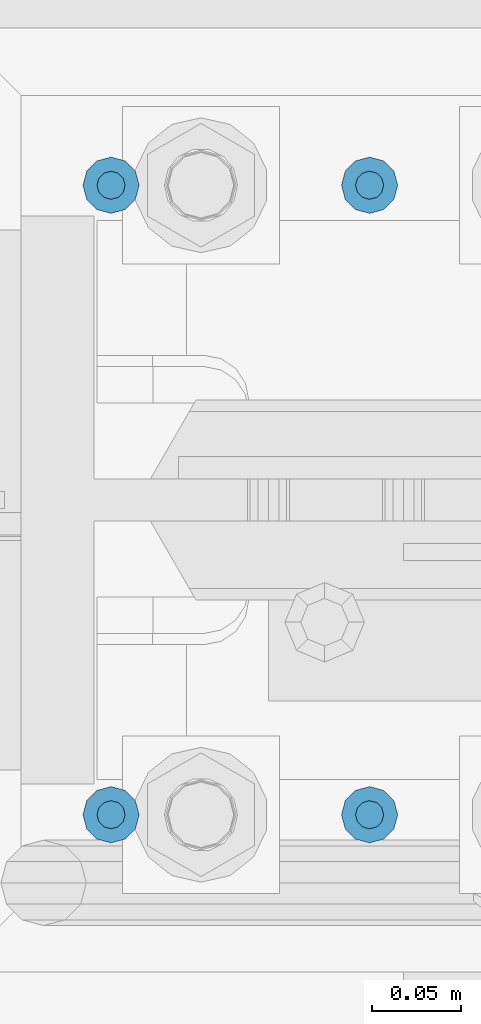
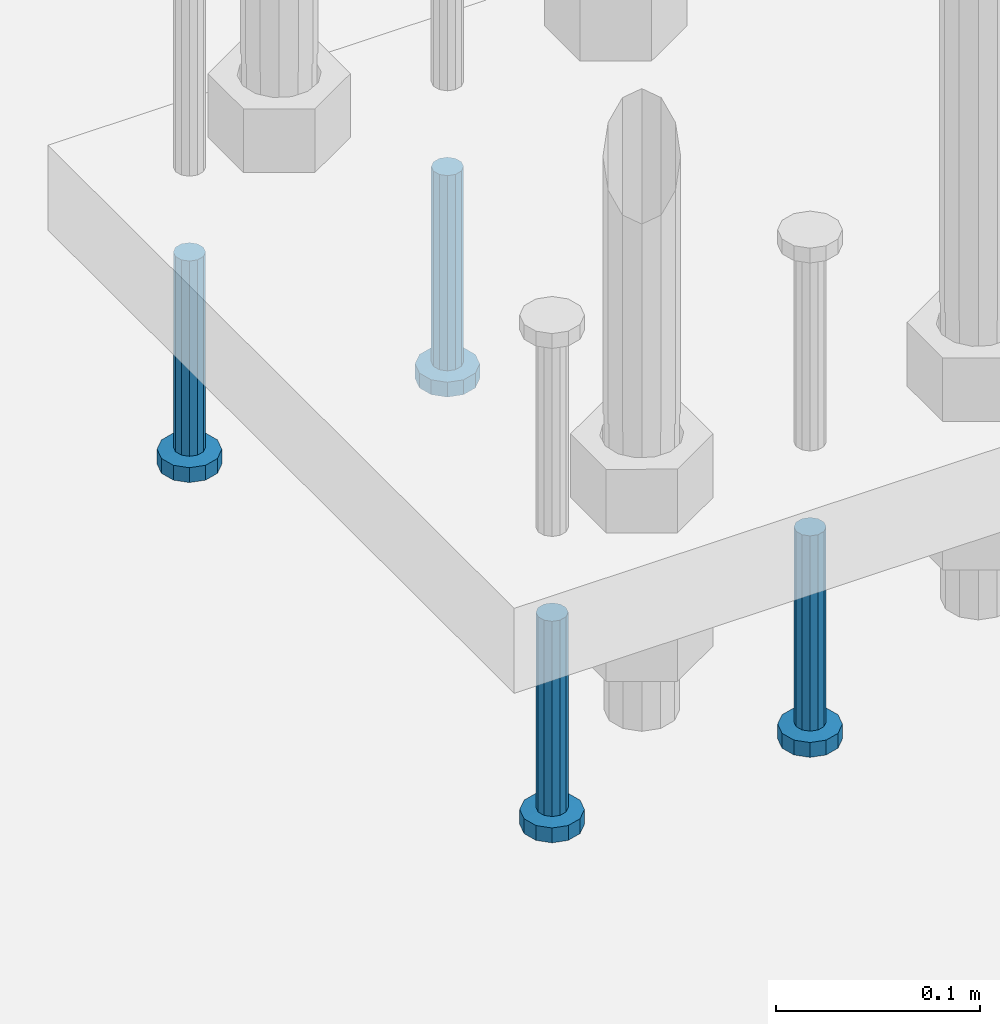
# One storey, part 1333 of 1876: 4 beams, 1 element without a shape of its own.
"""IFC2X3 building model written with IfcOpenShell, lengths in millimetres."""

import ifcopenshell
import ifcopenshell.guid

model = None  # the IFC model being written
_history = None  # IfcOwnerHistory: only IFC2X3 demands one
_inside = {}  # id of a spatial element -> (the spatial element, [elements in it])
_under = {}  # id of a project, library or spatial element -> (it, [spatial elements below it])
_declared = {}  # id of a project -> (the project, [libraries it declares])
_typed = {}  # id of a type object -> (the type object, [elements of that type])
_made_of = {}  # id of a material, layer set ... -> (it, [elements and type objects made of it])


def new_model(schema):
    """Start an empty IFC model of exactly this schema.

    Asked for "IFC4X3", IfcOpenShell would pick the latest addendum, in which some entities
    have other attributes; the version numbers below select the first issue.
    IFC2X3 requires an IfcOwnerHistory on every rooted entity: one is made here for all.
    """
    global model, _history
    if schema == "IFC4X3":
        model = ifcopenshell.file(schema_version=(4, 3, 0, 0))
    else:
        model = ifcopenshell.file(schema=schema)
    _inside.clear()
    _under.clear()
    _declared.clear()
    _typed.clear()
    _made_of.clear()
    _history = None
    if model.schema == "IFC2X3":
        org = make("IfcOrganization", Name="unknown")
        user = make(
            "IfcPersonAndOrganization",
            ThePerson=make("IfcPerson", FamilyName="unknown"),
            TheOrganization=org,
        )
        app = make(
            "IfcApplication",
            ApplicationDeveloper=org,
            Version="unknown",
            ApplicationFullName="unknown",
            ApplicationIdentifier="unknown",
        )
        _history = make(
            "IfcOwnerHistory",
            OwningUser=user,
            OwningApplication=app,
            ChangeAction="ADDED",
            CreationDate=0,
        )
    return model


def make(cls, **values):
    """One entity of the class cls with the attributes given. An attribute that is None is left unset."""
    return model.create_entity(
        cls, **{name: value for name, value in values.items() if value is not None}
    )


def rooted(cls, **values):
    """An entity with a GlobalId (a new one), such as an element, a storey or a relation."""
    return make(cls, GlobalId=ifcopenshell.guid.new(), OwnerHistory=_history, **values)


def si_unit(unit_type, name, prefix=None):
    """IfcSIUnit, for example si_unit("LENGTHUNIT", "METRE", prefix="MILLI")."""
    return make("IfcSIUnit", UnitType=unit_type, Prefix=prefix, Name=name)


def assignment(units):
    """IfcUnitAssignment: the units of a project."""
    return None if units is None else make("IfcUnitAssignment", Units=units)


def point(xyz):
    """IfcCartesianPoint."""
    return None if xyz is None else make("IfcCartesianPoint", Coordinates=xyz)


def direction(xyz):
    """IfcDirection."""
    return None if xyz is None else make("IfcDirection", DirectionRatios=xyz)


def frame(location, z_axis=None, x_axis=None):
    """IfcAxis2Placement3D, a coordinate frame: its origin and axes. An axis left out is left unset."""
    return make(
        "IfcAxis2Placement3D",
        Location=point(location),
        Axis=direction(z_axis),
        RefDirection=direction(x_axis),
    )


def origin_with_axes():
    """The frame at (0, 0, 0) with the z axis (0, 0, 1) and the x axis (1, 0, 0) written out."""
    return frame((0.0, 0.0, 0.0), z_axis=(0.0, 0.0, 1.0), x_axis=(1.0, 0.0, 0.0))


def place(relative_to, where):
    """IfcLocalPlacement: puts the frame where relative to a parent placement (None: the world)."""
    return make(
        "IfcLocalPlacement", PlacementRelTo=relative_to, RelativePlacement=where
    )


def context(
    kind, dimensions, precision=None, world=None, true_north=None, identifier=None
):
    """IfcGeometricRepresentationContext, for example the 3D "Model" context."""
    return make(
        "IfcGeometricRepresentationContext",
        ContextIdentifier=identifier,
        ContextType=kind,
        CoordinateSpaceDimension=dimensions,
        Precision=precision,
        WorldCoordinateSystem=world,
        TrueNorth=true_north,
    )


def subcontext(parent, identifier, kind, view, scale=None):
    """IfcGeometricRepresentationSubContext, for example "Body" below "Model"."""
    return make(
        "IfcGeometricRepresentationSubContext",
        ContextIdentifier=identifier,
        ContextType=kind,
        ParentContext=parent,
        TargetScale=scale,
        TargetView=view,
    )


def project(units=None, contexts=None):
    """IfcProject with its units and contexts."""
    return rooted(
        "IfcProject",
        Name="project",
        RepresentationContexts=contexts,
        UnitsInContext=assignment(units),
    )


def spatial(cls, under=None, at=None, **own):
    """A site, building, storey or space (cls), placed at a placement, below another one or the project."""
    s = rooted(cls, ObjectPlacement=at, **own)
    if under is not None:
        _under.setdefault(under.id(), (under, []))[1].append(s)
    return s


def faces_of(points, faces, orient=None, outer=None):
    """IfcFace entities. A face is a list of loops; a loop is a list of indices into points, from 0.

    orient and outer hold one flag for each loop. By default every Orientation is true, the
    first loop of a face is its IfcFaceOuterBound and the others are IfcFaceBound.
    """
    made = []
    for i, loops in enumerate(faces):
        bounds = []
        for j, loop in enumerate(loops):
            is_outer = j == 0 if outer is None else outer[i][j]
            bounds.append(
                make(
                    "IfcFaceOuterBound" if is_outer else "IfcFaceBound",
                    Bound=make("IfcPolyLoop", Polygon=[points[k] for k in loop]),
                    Orientation=True if orient is None else orient[i][j],
                )
            )
        made.append(make("IfcFace", Bounds=bounds))
    return made


def faceted_brep(points, faces, orient=None, outer=None, voids=None):
    """IfcFacetedBrep: a solid bounded by flat faces; with voids (closed shells), ...WithVoids."""
    shared = [point(p) for p in points]
    hull = make("IfcClosedShell", CfsFaces=faces_of(shared, faces, orient, outer))
    if voids is None:
        return make("IfcFacetedBrep", Outer=hull)
    return make(
        "IfcFacetedBrepWithVoids",
        Outer=hull,
        Voids=[
            make(cls, CfsFaces=faces_of(shared, fs, o, b)) for cls, fs, o, b in voids
        ],
    )


def shape(context_of_items, identifier, shape_type, items):
    """IfcShapeRepresentation: the items that make up one representation, for example the "Body"."""
    return make(
        "IfcShapeRepresentation",
        ContextOfItems=context_of_items,
        RepresentationIdentifier=identifier,
        RepresentationType=shape_type,
        Items=items,
    )


def material(Name=None, Category=None):
    """IfcMaterial."""
    return make("IfcMaterial", Name=Name, Category=Category)


def made_of(thing, what):
    """Note that an element or type object is made of a material, layer set ...; save() writes the relation."""
    if what is not None:
        _made_of.setdefault(what.id(), (what, []))[1].append(thing)
    return thing


def type_object(cls, material=None, **own):
    """A type object (cls), such as IfcWallType, which elements share."""
    return made_of(rooted(cls, **own), material)


def element(
    cls,
    number,
    at=None,
    inside=None,
    cuts=None,
    type_object=None,
    material=None,
    context=None,
    identifier="Body",
    shape_type=None,
    held_by="IfcProductDefinitionShape",
    body=None,
    shapes=None,
    **own,
):
    """One element of the class cls, such as IfcWall. Its Tag is "e" and its number.

    at: its placement. inside: the storey or other place that contains it. cuts: it is an
    opening in that element (IfcRelVoidsElement). A single representation is given by context,
    identifier, shape_type and body (its items); several are given by shapes. held_by: the class
    of the entity that holds the representations. save() writes the other relations.
    """
    e = rooted(cls, Tag="e%d" % number, ObjectPlacement=at, **own)
    if body is not None:
        shapes = [shape(context, identifier, shape_type, body)]
    if shapes is not None:
        e.Representation = make(held_by, Representations=shapes)
    if inside is not None:
        _inside.setdefault(inside.id(), (inside, []))[1].append(e)
    if cuts is not None:
        rooted(
            "IfcRelVoidsElement", RelatingBuildingElement=cuts, RelatedOpeningElement=e
        )
    if type_object is not None:
        _typed.setdefault(type_object.id(), (type_object, []))[1].append(e)
    return made_of(e, material)


def aggregate(whole, parts):
    """IfcRelAggregates: a whole, such as a stair, and the parts it consists of."""
    return rooted("IfcRelAggregates", RelatingObject=whole, RelatedObjects=parts)


def save(model, path):
    """Write the relations noted so far, then the file.

    IfcRelAggregates (storeys below a building ...), IfcRelContainedInSpatialStructure (elements
    in a storey), IfcRelDefinesByType, IfcRelAssociatesMaterial and IfcRelDeclares: one each for
    every whole, place, type object, material and project.
    """
    for whole, parts in _under.values():
        aggregate(whole, parts)
    for where, things in _inside.values():
        rooted(
            "IfcRelContainedInSpatialStructure",
            RelatedElements=things,
            RelatingStructure=where,
        )
    for kind, things in _typed.values():
        rooted("IfcRelDefinesByType", RelatedObjects=things, RelatingType=kind)
    for what, things in _made_of.values():
        rooted("IfcRelAssociatesMaterial", RelatedObjects=things, RelatingMaterial=what)
    for by, libraries in _declared.values():
        rooted("IfcRelDeclares", RelatingContext=by, RelatedDefinitions=libraries)
    model.write(path)


model = new_model("IFC2X3")

# Units and contexts
model_context = context("Model", 3, precision=1e-05, world=origin_with_axes())
body_context = subcontext(model_context, "Body", "Model", "MODEL_VIEW")
ifc_project = project(units=[si_unit("LENGTHUNIT", "METRE", prefix="MILLI"), si_unit("AREAUNIT", "SQUARE_METRE"), si_unit("VOLUMEUNIT", "CUBIC_METRE"), si_unit("MASSUNIT", "GRAM", prefix="KILO"), si_unit("TIMEUNIT", "SECOND"), si_unit("PLANEANGLEUNIT", "RADIAN"), si_unit("SOLIDANGLEUNIT", "STERADIAN"), si_unit("THERMODYNAMICTEMPERATUREUNIT", "DEGREE_CELSIUS"), si_unit("LUMINOUSINTENSITYUNIT", "LUMEN")], contexts=[model_context])

# Site, building, storey
site_placement = place(None, origin_with_axes())
site = spatial("IfcSite", under=ifc_project, at=site_placement, CompositionType="ELEMENT")
building_placement = place(site_placement, origin_with_axes())
building = spatial("IfcBuilding", under=site, at=building_placement, Name="Undefined", CompositionType="ELEMENT")
storey_placement = place(building_placement, origin_with_axes())
storey = spatial("IfcBuildingStorey", under=building, at=storey_placement, Name="Undefined", CompositionType="ELEMENT", Elevation=0.0)

# Assembly, beams
assembly_placement = place(storey_placement, origin_with_axes())
assembly = element("IfcElementAssembly", 1, at=assembly_placement, inside=storey, Name="TEMPLATE", AssemblyPlace="NOTDEFINED", PredefinedType="RIGID_FRAME")
ifc_material = material(Name="STEEL/A108")
beam_type = type_object("IfcBeamType", Name="5/8-DIA_HEADED ANCHOR STUD", PredefinedType="NOTDEFINED")
beam_1_placement = place(assembly_placement, frame((7378.7, 13893.8, -787.4), z_axis=(1.0, 0.0, 0.0), x_axis=(0.0, 0.0, -1.0)))
beam_1 = element("IfcBeam", 2, at=beam_1_placement, type_object=beam_type, material=ifc_material, Name="HEADED ANCHOR STUD", ObjectType="5/8-DIA_HEADED ANCHOR STUD", context=body_context, shape_type="Brep", body=[
    faceted_brep([(0.0, -7.94000005722046, 0.0), (0.0, -6.86999988555908, -3.97000002861023), (116.84, -6.86999988555908, -3.97000002861023), (116.84, -7.94000005722046, 0.0), (0.0, -3.97000002861023, -6.86999988555908), (116.84, -3.97000002861023, -6.86999988555908), (0.0, 0.0, -7.94000005722046), (116.84, 0.0, -7.94000005722046), (0.0, 3.97000002861023, -6.86999988555908), (116.84, 3.97000002861023, -6.86999988555908), (0.0, 6.86999988555908, -3.97000002861023), (116.84, 6.86999988555908, -3.97000002861023), (0.0, 7.94000005722046, 0.0), (116.84, 7.94000005722046, 0.0), (0.0, 6.86999988555908, 3.97000002861023), (116.84, 6.86999988555908, 3.97000002861023), (0.0, 3.97000002861023, 6.86999988555908), (116.84, 3.97000002861023, 6.86999988555908), (0.0, 0.0, 7.94000005722046), (116.84, 0.0, 7.94000005722046), (0.0, -3.97000002861023, 6.86999988555908), (116.84, -3.97000002861023, 6.86999988555908), (0.0, -6.86999988555908, 3.97000002861023), (116.84, -6.86999988555908, 3.97000002861023), (118.11, -13.75, -7.94000005722046), (118.11, -15.8800001144409, 0.0), (118.11, -7.94000005722046, -13.75), (118.11, 0.0, -15.8800001144409), (118.11, 7.94000005722046, -13.75), (118.11, 13.75, -7.94000005722046), (118.11, 15.8800001144409, 0.0), (118.11, 13.75, 7.94000005722046), (118.11, 7.94000005722046, 13.75), (118.11, 0.0, 15.8800001144409), (118.11, -7.94000005722046, 13.75), (118.11, -13.75, 7.94000005722046), (127.0, -13.75, -7.94000005722046), (127.0, -15.8800001144409, 0.0), (127.0, -7.94000005722046, -13.75), (127.0, 0.0, -15.8800001144409), (127.0, 7.94000005722046, -13.75), (127.0, 13.75, -7.94000005722046), (127.0, 15.8800001144409, 0.0), (127.0, 13.75, 7.94000005722046), (127.0, 7.94000005722046, 13.75), (127.0, 0.0, 15.8800001144409), (127.0, -7.94000005722046, 13.75), (127.0, -13.75, 7.94000005722046)], [[[0, 1, 2, 3]], [[1, 4, 5, 2]], [[4, 6, 7, 5]], [[6, 8, 9, 7]], [[8, 10, 11, 9]], [[10, 12, 13, 11]], [[12, 14, 15, 13]], [[14, 16, 17, 15]], [[16, 18, 19, 17]], [[18, 20, 21, 19]], [[20, 22, 23, 21]], [[22, 0, 3, 23]], [[22, 20, 18, 16, 14, 12, 10, 8, 6, 4, 1, 0]], [[3, 2, 24, 25]], [[2, 5, 26, 24]], [[5, 7, 27, 26]], [[7, 9, 28, 27]], [[9, 11, 29, 28]], [[11, 13, 30, 29]], [[13, 15, 31, 30]], [[15, 17, 32, 31]], [[17, 19, 33, 32]], [[19, 21, 34, 33]], [[21, 23, 35, 34]], [[23, 3, 25, 35]], [[25, 24, 36, 37]], [[24, 26, 38, 36]], [[26, 27, 39, 38]], [[27, 28, 40, 39]], [[28, 29, 41, 40]], [[29, 30, 42, 41]], [[30, 31, 43, 42]], [[31, 32, 44, 43]], [[32, 33, 45, 44]], [[33, 34, 46, 45]], [[34, 35, 47, 46]], [[35, 25, 37, 47]], [[38, 39, 40, 41, 42, 43, 44, 45, 46, 47, 37, 36]]]),
])
beam_2_placement = place(assembly_placement, frame((7378.7, 13538.2, -787.4), z_axis=(1.0, 0.0, 0.0), x_axis=(0.0, 0.0, -1.0)))
beam_2 = element("IfcBeam", 3, at=beam_2_placement, type_object=beam_type, material=ifc_material, Name="HEADED ANCHOR STUD", ObjectType="5/8-DIA_HEADED ANCHOR STUD", context=body_context, shape_type="Brep", body=[
    faceted_brep([(0.0, -7.94000005722046, 0.0), (0.0, -6.86999988555908, -3.97000002861023), (116.84, -6.86999988555908, -3.97000002861023), (116.84, -7.94000005722046, 0.0), (0.0, -3.97000002861023, -6.86999988555908), (116.84, -3.97000002861023, -6.86999988555908), (0.0, 0.0, -7.94000005722046), (116.84, 0.0, -7.94000005722046), (0.0, 3.97000002861023, -6.86999988555908), (116.84, 3.97000002861023, -6.86999988555908), (0.0, 6.86999988555908, -3.97000002861023), (116.84, 6.86999988555908, -3.97000002861023), (0.0, 7.94000005722046, 0.0), (116.84, 7.94000005722046, 0.0), (0.0, 6.86999988555908, 3.97000002861023), (116.84, 6.86999988555908, 3.97000002861023), (0.0, 3.97000002861023, 6.86999988555908), (116.84, 3.97000002861023, 6.86999988555908), (0.0, 0.0, 7.94000005722046), (116.84, 0.0, 7.94000005722046), (0.0, -3.97000002861023, 6.86999988555908), (116.84, -3.97000002861023, 6.86999988555908), (0.0, -6.86999988555908, 3.97000002861023), (116.84, -6.86999988555908, 3.97000002861023), (118.11, -13.75, -7.94000005722046), (118.11, -15.8800001144409, 0.0), (118.11, -7.94000005722046, -13.75), (118.11, 0.0, -15.8800001144409), (118.11, 7.94000005722046, -13.75), (118.11, 13.75, -7.94000005722046), (118.11, 15.8800001144409, 0.0), (118.11, 13.75, 7.94000005722046), (118.11, 7.94000005722046, 13.75), (118.11, 0.0, 15.8800001144409), (118.11, -7.94000005722046, 13.75), (118.11, -13.75, 7.94000005722046), (127.0, -13.75, -7.94000005722046), (127.0, -15.8800001144409, 0.0), (127.0, -7.94000005722046, -13.75), (127.0, 0.0, -15.8800001144409), (127.0, 7.94000005722046, -13.75), (127.0, 13.75, -7.94000005722046), (127.0, 15.8800001144409, 0.0), (127.0, 13.75, 7.94000005722046), (127.0, 7.94000005722046, 13.75), (127.0, 0.0, 15.8800001144409), (127.0, -7.94000005722046, 13.75), (127.0, -13.75, 7.94000005722046)], [[[0, 1, 2, 3]], [[1, 4, 5, 2]], [[4, 6, 7, 5]], [[6, 8, 9, 7]], [[8, 10, 11, 9]], [[10, 12, 13, 11]], [[12, 14, 15, 13]], [[14, 16, 17, 15]], [[16, 18, 19, 17]], [[18, 20, 21, 19]], [[20, 22, 23, 21]], [[22, 0, 3, 23]], [[22, 20, 18, 16, 14, 12, 10, 8, 6, 4, 1, 0]], [[3, 2, 24, 25]], [[2, 5, 26, 24]], [[5, 7, 27, 26]], [[7, 9, 28, 27]], [[9, 11, 29, 28]], [[11, 13, 30, 29]], [[13, 15, 31, 30]], [[15, 17, 32, 31]], [[17, 19, 33, 32]], [[19, 21, 34, 33]], [[21, 23, 35, 34]], [[23, 3, 25, 35]], [[25, 24, 36, 37]], [[24, 26, 38, 36]], [[26, 27, 39, 38]], [[27, 28, 40, 39]], [[28, 29, 41, 40]], [[29, 30, 42, 41]], [[30, 31, 43, 42]], [[31, 32, 44, 43]], [[32, 33, 45, 44]], [[33, 34, 46, 45]], [[34, 35, 47, 46]], [[35, 25, 37, 47]], [[38, 39, 40, 41, 42, 43, 44, 45, 46, 47, 37, 36]]]),
])
beam_3_placement = place(assembly_placement, frame((7524.75, 13893.8, -787.4), z_axis=(1.0, 0.0, 0.0), x_axis=(0.0, 0.0, -1.0)))
beam_3 = element("IfcBeam", 4, at=beam_3_placement, type_object=beam_type, material=ifc_material, Name="HEADED ANCHOR STUD", ObjectType="5/8-DIA_HEADED ANCHOR STUD", context=body_context, shape_type="Brep", body=[
    faceted_brep([(0.0, -7.94000005722046, 0.0), (0.0, -6.86999988555908, -3.97000002861023), (116.84, -6.86999988555908, -3.97000002861023), (116.84, -7.94000005722046, 0.0), (0.0, -3.97000002861023, -6.86999988555908), (116.84, -3.97000002861023, -6.86999988555908), (0.0, 0.0, -7.94000005722046), (116.84, 0.0, -7.94000005722046), (0.0, 3.97000002861023, -6.86999988555908), (116.84, 3.97000002861023, -6.86999988555908), (0.0, 6.86999988555908, -3.97000002861023), (116.84, 6.86999988555908, -3.97000002861023), (0.0, 7.94000005722046, 0.0), (116.84, 7.94000005722046, 0.0), (0.0, 6.86999988555908, 3.97000002861023), (116.84, 6.86999988555908, 3.97000002861023), (0.0, 3.97000002861023, 6.86999988555908), (116.84, 3.97000002861023, 6.86999988555908), (0.0, 0.0, 7.94000005722046), (116.84, 0.0, 7.94000005722046), (0.0, -3.97000002861023, 6.86999988555908), (116.84, -3.97000002861023, 6.86999988555908), (0.0, -6.86999988555908, 3.97000002861023), (116.84, -6.86999988555908, 3.97000002861023), (118.11, -13.75, -7.94000005722046), (118.11, -15.8800001144409, 0.0), (118.11, -7.94000005722046, -13.75), (118.11, 0.0, -15.8800001144409), (118.11, 7.94000005722046, -13.75), (118.11, 13.75, -7.94000005722046), (118.11, 15.8800001144409, 0.0), (118.11, 13.75, 7.94000005722046), (118.11, 7.94000005722046, 13.75), (118.11, 0.0, 15.8800001144409), (118.11, -7.94000005722046, 13.75), (118.11, -13.75, 7.94000005722046), (127.0, -13.75, -7.94000005722046), (127.0, -15.8800001144409, 0.0), (127.0, -7.94000005722046, -13.75), (127.0, 0.0, -15.8800001144409), (127.0, 7.94000005722046, -13.75), (127.0, 13.75, -7.94000005722046), (127.0, 15.8800001144409, 0.0), (127.0, 13.75, 7.94000005722046), (127.0, 7.94000005722046, 13.75), (127.0, 0.0, 15.8800001144409), (127.0, -7.94000005722046, 13.75), (127.0, -13.75, 7.94000005722046)], [[[0, 1, 2, 3]], [[1, 4, 5, 2]], [[4, 6, 7, 5]], [[6, 8, 9, 7]], [[8, 10, 11, 9]], [[10, 12, 13, 11]], [[12, 14, 15, 13]], [[14, 16, 17, 15]], [[16, 18, 19, 17]], [[18, 20, 21, 19]], [[20, 22, 23, 21]], [[22, 0, 3, 23]], [[22, 20, 18, 16, 14, 12, 10, 8, 6, 4, 1, 0]], [[3, 2, 24, 25]], [[2, 5, 26, 24]], [[5, 7, 27, 26]], [[7, 9, 28, 27]], [[9, 11, 29, 28]], [[11, 13, 30, 29]], [[13, 15, 31, 30]], [[15, 17, 32, 31]], [[17, 19, 33, 32]], [[19, 21, 34, 33]], [[21, 23, 35, 34]], [[23, 3, 25, 35]], [[25, 24, 36, 37]], [[24, 26, 38, 36]], [[26, 27, 39, 38]], [[27, 28, 40, 39]], [[28, 29, 41, 40]], [[29, 30, 42, 41]], [[30, 31, 43, 42]], [[31, 32, 44, 43]], [[32, 33, 45, 44]], [[33, 34, 46, 45]], [[34, 35, 47, 46]], [[35, 25, 37, 47]], [[38, 39, 40, 41, 42, 43, 44, 45, 46, 47, 37, 36]]]),
])
beam_4_placement = place(assembly_placement, frame((7524.75, 13538.2, -787.4), z_axis=(1.0, 0.0, 0.0), x_axis=(0.0, 0.0, -1.0)))
beam_4 = element("IfcBeam", 5, at=beam_4_placement, type_object=beam_type, material=ifc_material, Name="HEADED ANCHOR STUD", ObjectType="5/8-DIA_HEADED ANCHOR STUD", context=body_context, shape_type="Brep", body=[
    faceted_brep([(0.0, -7.94000005722046, 0.0), (0.0, -6.86999988555908, -3.97000002861023), (116.84, -6.86999988555908, -3.97000002861023), (116.84, -7.94000005722046, 0.0), (0.0, -3.97000002861023, -6.86999988555908), (116.84, -3.97000002861023, -6.86999988555908), (0.0, 0.0, -7.94000005722046), (116.84, 0.0, -7.94000005722046), (0.0, 3.97000002861023, -6.86999988555908), (116.84, 3.97000002861023, -6.86999988555908), (0.0, 6.86999988555908, -3.97000002861023), (116.84, 6.86999988555908, -3.97000002861023), (0.0, 7.94000005722046, 0.0), (116.84, 7.94000005722046, 0.0), (0.0, 6.86999988555908, 3.97000002861023), (116.84, 6.86999988555908, 3.97000002861023), (0.0, 3.97000002861023, 6.86999988555908), (116.84, 3.97000002861023, 6.86999988555908), (0.0, 0.0, 7.94000005722046), (116.84, 0.0, 7.94000005722046), (0.0, -3.97000002861023, 6.86999988555908), (116.84, -3.97000002861023, 6.86999988555908), (0.0, -6.86999988555908, 3.97000002861023), (116.84, -6.86999988555908, 3.97000002861023), (118.11, -13.75, -7.94000005722046), (118.11, -15.8800001144409, 0.0), (118.11, -7.94000005722046, -13.75), (118.11, 0.0, -15.8800001144409), (118.11, 7.94000005722046, -13.75), (118.11, 13.75, -7.94000005722046), (118.11, 15.8800001144409, 0.0), (118.11, 13.75, 7.94000005722046), (118.11, 7.94000005722046, 13.75), (118.11, 0.0, 15.8800001144409), (118.11, -7.94000005722046, 13.75), (118.11, -13.75, 7.94000005722046), (127.0, -13.75, -7.94000005722046), (127.0, -15.8800001144409, 0.0), (127.0, -7.94000005722046, -13.75), (127.0, 0.0, -15.8800001144409), (127.0, 7.94000005722046, -13.75), (127.0, 13.75, -7.94000005722046), (127.0, 15.8800001144409, 0.0), (127.0, 13.75, 7.94000005722046), (127.0, 7.94000005722046, 13.75), (127.0, 0.0, 15.8800001144409), (127.0, -7.94000005722046, 13.75), (127.0, -13.75, 7.94000005722046)], [[[0, 1, 2, 3]], [[1, 4, 5, 2]], [[4, 6, 7, 5]], [[6, 8, 9, 7]], [[8, 10, 11, 9]], [[10, 12, 13, 11]], [[12, 14, 15, 13]], [[14, 16, 17, 15]], [[16, 18, 19, 17]], [[18, 20, 21, 19]], [[20, 22, 23, 21]], [[22, 0, 3, 23]], [[22, 20, 18, 16, 14, 12, 10, 8, 6, 4, 1, 0]], [[3, 2, 24, 25]], [[2, 5, 26, 24]], [[5, 7, 27, 26]], [[7, 9, 28, 27]], [[9, 11, 29, 28]], [[11, 13, 30, 29]], [[13, 15, 31, 30]], [[15, 17, 32, 31]], [[17, 19, 33, 32]], [[19, 21, 34, 33]], [[21, 23, 35, 34]], [[23, 3, 25, 35]], [[25, 24, 36, 37]], [[24, 26, 38, 36]], [[26, 27, 39, 38]], [[27, 28, 40, 39]], [[28, 29, 41, 40]], [[29, 30, 42, 41]], [[30, 31, 43, 42]], [[31, 32, 44, 43]], [[32, 33, 45, 44]], [[33, 34, 46, 45]], [[34, 35, 47, 46]], [[35, 25, 37, 47]], [[38, 39, 40, 41, 42, 43, 44, 45, 46, 47, 37, 36]]]),
])
aggregate(assembly, [beam_1, beam_2, beam_3, beam_4])

save(model, "model.ifc")
